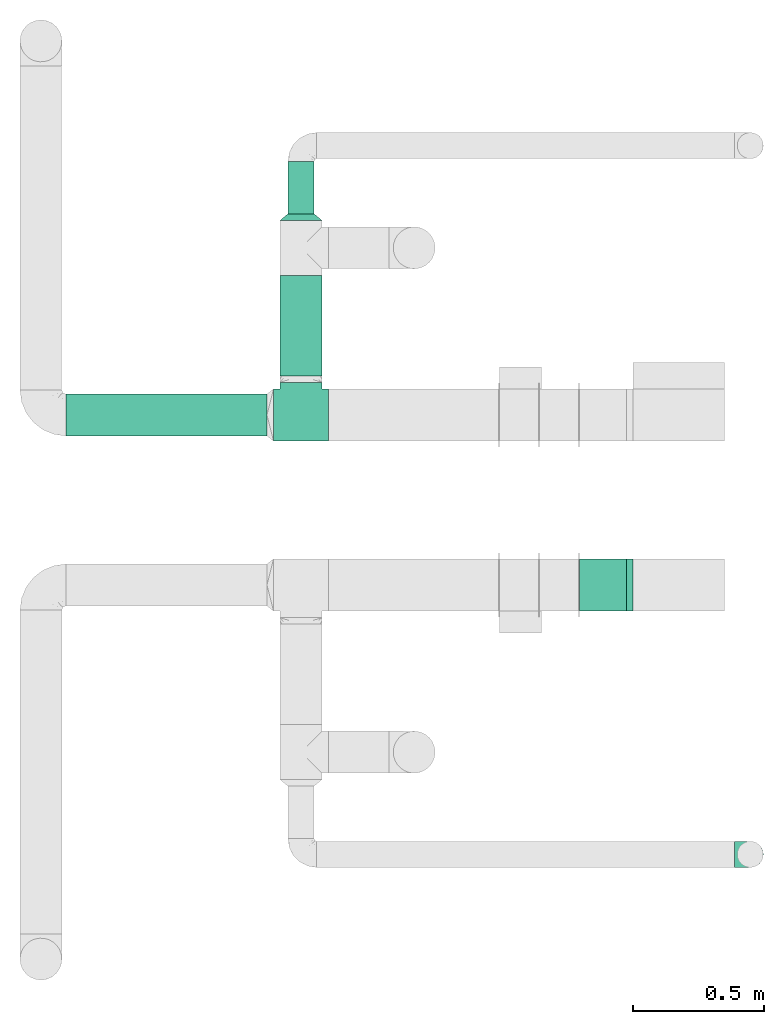
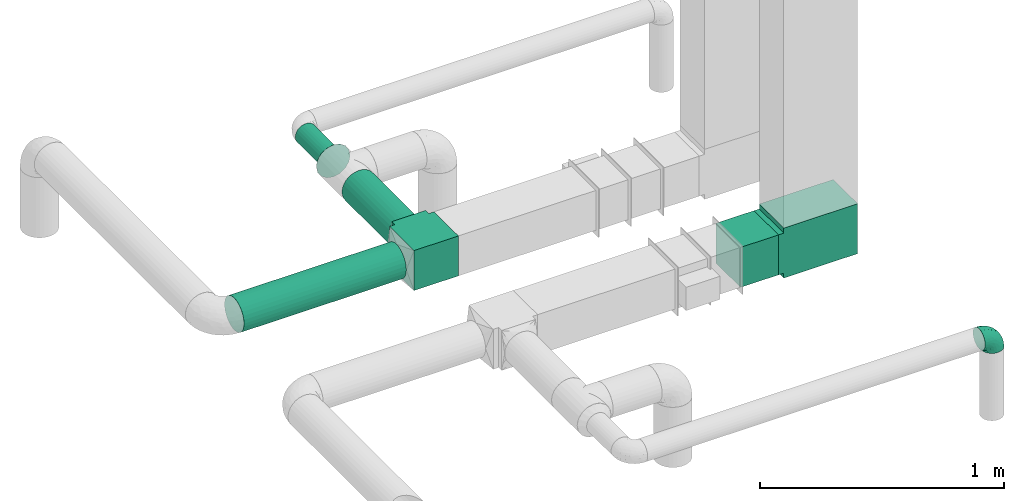
# One storey, part 6 of 12: 4 flow fittings, 4 flow segments.
"""IFC2X3 building model written with IfcOpenShell, lengths in millimetres."""

from ifc_helpers import new_model, entity, si_unit, converted_unit, derived_unit, direction, frame, frame_2d, origin, origin_2d_with_axis, place, context, subcontext, project, spatial, polyline, rectangle, circle, outline, extrude, faceted_brep, source, transform, mapped, material, type_object, type_shapes, element, save


model = new_model("IFC2X3")

# Units and contexts
model_context = context("Model", 3, precision=0.01, world=origin(), true_north=direction((6.12303176911189e-17, 1.0)))
body_context = subcontext(model_context, "Body", "Model", "MODEL_VIEW")
ifc_project = project(units=[si_unit("LENGTHUNIT", "METRE", prefix="MILLI"), si_unit("AREAUNIT", "SQUARE_METRE"), si_unit("VOLUMEUNIT", "CUBIC_METRE"), converted_unit("PLANEANGLEUNIT", "DEGREE", entity("IfcRatioMeasure", 0.0174532925199433), si_unit("PLANEANGLEUNIT", "RADIAN"), dimensions=[0, 0, 0, 0, 0, 0, 0]), si_unit("MASSUNIT", "GRAM", prefix="KILO"), derived_unit("MASSDENSITYUNIT", [(si_unit("MASSUNIT", "GRAM", prefix="KILO"), 1), (si_unit("LENGTHUNIT", "METRE"), -3)]), si_unit("TIMEUNIT", "SECOND"), si_unit("FREQUENCYUNIT", "HERTZ"), si_unit("THERMODYNAMICTEMPERATUREUNIT", "DEGREE_CELSIUS"), derived_unit("THERMALTRANSMITTANCEUNIT", [(si_unit("MASSUNIT", "GRAM", prefix="KILO"), 1), (si_unit("THERMODYNAMICTEMPERATUREUNIT", "KELVIN"), -1), (si_unit("TIMEUNIT", "SECOND"), -3)]), derived_unit("VOLUMETRICFLOWRATEUNIT", [(si_unit("LENGTHUNIT", "METRE"), 3), (si_unit("TIMEUNIT", "SECOND"), -1)]), si_unit("ELECTRICCURRENTUNIT", "AMPERE"), si_unit("ELECTRICVOLTAGEUNIT", "VOLT"), si_unit("POWERUNIT", "WATT"), si_unit("FORCEUNIT", "NEWTON", prefix="KILO"), si_unit("ILLUMINANCEUNIT", "LUX"), si_unit("LUMINOUSFLUXUNIT", "LUMEN"), si_unit("LUMINOUSINTENSITYUNIT", "CANDELA"), derived_unit("USERDEFINED", [(si_unit("MASSUNIT", "GRAM", prefix="KILO"), -1), (si_unit("LENGTHUNIT", "METRE"), -2), (si_unit("TIMEUNIT", "SECOND"), 3), (si_unit("LUMINOUSFLUXUNIT", "LUMEN"), 1)]), derived_unit("LINEARVELOCITYUNIT", [(si_unit("LENGTHUNIT", "METRE"), 1), (si_unit("TIMEUNIT", "SECOND"), -1)]), si_unit("PRESSUREUNIT", "PASCAL"), derived_unit("USERDEFINED", [(si_unit("LENGTHUNIT", "METRE"), -2), (si_unit("MASSUNIT", "GRAM", prefix="KILO"), 1), (si_unit("TIMEUNIT", "SECOND"), -2)])], contexts=[model_context])

# Site, building, storey
site_placement = place(None, origin())
site = spatial("IfcSite", under=ifc_project, at=site_placement, CompositionType="ELEMENT")
building_placement = place(site_placement, origin())
building = spatial("IfcBuilding", under=site, at=building_placement, CompositionType="ELEMENT")
storey_placement = place(building_placement, frame((0.0, 0.0, 4000.0)))
storey = spatial("IfcBuildingStorey", under=building, at=storey_placement, Name="01 Level", CompositionType="ELEMENT", Elevation=4000.0)

# Flow segments
duct_segment_type_1 = type_object("IfcDuctSegmentType", Name="Round Duct:Air", PredefinedType="NOTDEFINED")
flow_segment_1_placement = place(storey_placement, frame((22287.748982204, -68588.0392131986, 2918.40472776409)))
element("IfcFlowSegment", 1, at=flow_segment_1_placement, inside=storey, type_object=duct_segment_type_1, Name="Round Duct:Air", ObjectType="Round Duct:Air", context=body_context, shape_type="SweptSolid", body=[
    extrude(circle(Radius=80.0, at=origin_2d_with_axis()), frame((0.0, 81.5952722359237, 81.5952722359161), z_axis=(1.0, 0.0, 0.0), x_axis=(0.0, -1.0, 0.0)), (0.0, 0.0, 1.0), 768.241088647822),
])
flow_segment_2_placement = place(storey_placement, frame((23134.3947986159, -67737.2449387878, 2948.40472776403)))
element("IfcFlowSegment", 2, at=flow_segment_2_placement, inside=storey, type_object=duct_segment_type_1, Name="Round Duct:Air", ObjectType="Round Duct:Air", context=body_context, shape_type="SweptSolid", body=[
    extrude(circle(Radius=50.0, at=origin_2d_with_axis()), frame((51.5952722359175, 0.0, 51.5952722359164), z_axis=(0.0, 1.0, 0.0), x_axis=(-1.0, 0.0, 0.0)), (0.0, 0.0, 1.0), 200.701380999497),
])
flow_segment_3_placement = place(storey_placement, frame((23104.3947986159, -68356.4439409626, 2918.40472776409)))
element("IfcFlowSegment", 3, at=flow_segment_3_placement, inside=storey, type_object=duct_segment_type_1, Name="Round Duct:Air", ObjectType="Round Duct:Air", context=body_context, shape_type="SweptSolid", body=[
    extrude(circle(Radius=80.0, at=origin_2d_with_axis()), frame((81.595272235915, 0.0, 81.595272235915), z_axis=(0.0, 1.0, 0.0), x_axis=(-1.0, 0.0, 0.0)), (0.0, 0.0, 1.0), 384.199002174792),
])

# Flow fitting
duct_fitting_type_1 = type_object("IfcDuctFittingType", Name="Air_Elbow short_Circ", PredefinedType="NOTDEFINED")
shared_shape_1 = source(origin(), body_context, "Body", "Brep", [
    faceted_brep([(-60.0, 0.0, -50.0), (-60.0, -12.9409522551259, -48.2962913144534), (-60.0, -25.0, -43.3012701892219), (-60.0, -35.3553390593273, -35.3553390593274), (-60.0, -43.3012701892218, -25.0), (-60.0, -48.2962913144533, -12.9409522551262), (-60.0, -50.0, 0.0), (-60.0, -48.2962913144534, 12.9409522551259), (-60.0, -43.301270189222, 25.0), (-60.0, -35.3553390593275, 35.3553390593272), (-60.0, -25.0, 43.3012701892218), (-60.0, -12.9409522551262, 48.2962913144533), (-60.0, 0.0, 50.0), (-60.0, 12.9409522551258, 48.2962913144534), (-60.0, 18.9704761275628, 45.7987807518377), (-60.0, 25.0, 43.301270189222), (-60.0, 35.3553390593271, 35.3553390593275), (-60.0, 43.3012701892217, 25.0), (-60.0, 48.2962913144533, 12.9409522551263), (-60.0, 50.0, 0.0), (-60.0, 48.2962913144534, -12.940952255126), (-60.0, 43.3012701892219, -25.0), (-60.0, 35.3553390593274, -35.3553390593273), (-60.0, 25.0, -43.3012701892219), (-60.0, 12.9409522551261, -48.2962913144533), (-12.9409522551252, 60.0, -48.2962913144533), (-18.9704761275622, 60.0, -45.7987807518376), (-25.0, 60.0, -43.3012701892219), (-35.3553390593265, 60.0, -35.3553390593273), (-43.301270189221, 60.0, -25.0), (-48.2962913144525, 60.0, -12.940952255126), (-50.0, 60.0, 0.0), (-48.2962913144524, 60.0, 12.9409522551263), (-43.3012701892209, 60.0, 25.0), (-35.3553390593263, 60.0, 35.3553390593275), (-25.0, 60.0, 43.301270189222), (-12.9409522551249, 60.0, 48.2962913144534), (0.0, 60.0, 50.0), (12.9409522551271, 60.0, 48.2962913144533), (25.0, 60.0, 43.3012701892218), (35.3553390593284, 60.0, 35.3553390593272), (43.3012701892229, 60.0, 25.0), (48.2962913144543, 60.0, 12.9409522551259), (50.0, 60.0, 0.0), (48.2962913144542, 60.0, -12.9409522551262), (43.3012701892227, 60.0, -25.0), (35.3553390593281, 60.0, -35.3553390593274), (25.0, 60.0, -43.3012701892219), (12.9409522551268, 60.0, -48.2962913144534), (0.0, 60.0, -50.0), (-49.0564079906538, -40.7801415025898, 28.076858272246), (-41.7413930879589, -46.3367006663211, 14.3622192349088), (-34.4613055182162, -40.2781615499549, 24.6893391361235), (-43.0040653093767, -47.3081083962334, 0.0), (-49.945230570524, 14.009456366224, 48.3010541644054), (-46.9531334224505, 28.9691372331723, 42.5007483631415), (46.3367008388525, 41.7413924405609, 14.3622183025403), (-20.8886043148544, -37.032907476011, 22.5646988156665), (-16.4026032888538, -28.8335615486346, 31.3447155376829), (-28.9195822317624, -34.3595042325614, 30.8522337271345), (18.1051423029501, 18.6630708487668, 41.1725129713058), (21.5851347328685, 39.3600400603544, 43.7780030266717), (8.51327307359233, 29.8490270681828, 47.7425705251578), (-16.993357552601, 43.112835299455, 48.0588376259554), (-3.94145017646366, 44.1513377558611, 49.9695692624666), (-39.360041631582, -21.585137213725, 43.7780019122438), (-18.6630773197735, -18.1051465687322, 41.1725124591201), (-29.8490305613342, -8.51327565171467, 47.7425702287428), (-41.9572959526986, -32.3456520264411, 36.575294220854), (-28.3738768436699, -26.9110252548877, 38.0083212356069), (-51.9080682539527, 51.9080682564403, 11.9284381035673), (-47.8035915916317, 49.3365848090307, 24.1167211667097), (-28.9388870718402, 47.4392187660381, 42.4028289139121), (-46.4119732313288, -8.97786791845547, 48.9268647037242), (-0.0901680697707372, -16.249793899354, 33.6631038709893), (12.7026747916207, -16.0653579926251, 21.330563165355), (15.3655862372502, -1.44443599762982, 33.3656926605527), (-40.3512409746586, 17.2001159603688, 48.3058104561749), (-43.5357165770215, 3.92607608695299, 49.9756911723036), (-26.0984306641832, 9.4519602521943, 49.9925353018775), (-51.5116032222349, 38.9116886125261, 33.3337470302399), (32.3456522233896, 41.9572963751397, 36.5752941161915), (34.3595052098631, 28.9195768148052, 30.852230382061), (40.2781623134548, 34.4613024546835, 24.689336501659), (-52.6192947824697, 44.3162483434043, 26.0687788699409), (8.97786691245749, 46.4119718726044, 48.9268648562795), (35.0507691245895, 17.8379542600364, 23.7817320689175), (-10.9191638901366, -35.9593562872322, 14.7243484546897), (0.164802122834046, -30.9507973718637, 9.70158150296541), (-0.154113830211583, -27.0441585303382, 20.4371969134619), (40.7801421145919, 49.0564069362065, 28.0768572079665), (42.5446020921407, 25.3772134428819, 13.1791087429088), (10.303795037543, -23.1674391280597, 10.425151792526), (23.1044280783399, -10.2139010010231, 10.911201952746), (44.6162167924678, 26.008130618756, 0.0), (47.3081083962343, 43.0040653093781, 0.0), (-41.6246972537655, 41.624696659769, 36.6481760707585), (-32.7984308187714, 33.1644722725009, 45.0025999357929), (-7.74597844975689, 15.8760781607658, 49.2907901610601), (-16.0198594588589, 0.790040969679908, 48.0702532559686), (-10.2505184648613, 32.0701285913551, 49.9130990257927), (-52.9289321881336, 52.9289321881345, 0.0), (-38.9116885130941, 51.5116028691678, 33.3337472807585), (28.8335585354312, 16.4025932897411, 31.3447134244473), (27.3373523634918, 28.9262874076833, 37.8242669720924), (-10.6758764332908, -36.8040430868554, 0.0), (-21.0820556464647, 25.013405385062, 49.4085637061446), (-25.3772163464242, -42.5446022063287, 13.179111746218), (-29.4708300504911, 18.1716321771538, 49.3204506255928), (-0.613576836584022, 32.0726800049485, 49.6825501479137), (-26.0081306187546, -44.6162167924668, 0.0), (7.809323786389, 12.5506490133832, 44.518448707346), (-1.21981718883359, 1.21981162112378, 44.3295369128094), (4.65637775217312, -28.991869381244, 0.0), (25.4694098156993, -0.899564345657441, 21.9045256717261), (30.9271083665945, -0.192011278925337, 9.72551394481069), (36.8040430868565, 10.6758764332921, 0.0), (8.17237141004653, 0.709602060124845, 39.7363553078916), (-1.20691178924098, -8.42774890414073, 39.8368437988478), (-11.8311378719951, -8.12805454147699, 44.1670059112514), (16.8241235667092, -16.8241235667079, 0.0), (35.9593546638031, 10.9191599029529, 14.7243472530362), (28.9918693812452, -4.65637775217184, 0.0), (-14.0094588862512, 49.9452236085703, -48.3010539035587), (-41.7413926252934, -46.3367005832334, -14.3622192468898), (-34.4613048910139, -40.2781614393135, -24.6893390523416), (-25.3772156484835, -42.5446019119684, -13.1791119497906), (-43.1128355702084, 16.9933564311214, -48.0588378972243), (-44.1513388294639, 3.94144876101963, -49.969569299814), (-49.3365851024771, 47.8035917204495, -24.1167206397972), (-41.62469790636, 41.6246960630329, -36.6481760341003), (-51.5116035577561, 38.9116884747343, -33.3337470330805), (23.1674375203698, -10.3037953844737, -10.4251565011195), (10.2138986720569, -23.1044286164337, -10.9112068363266), (16.0653446591387, -12.7026862735946, -21.330566780897), (35.9593546209329, 10.9191616413996, -14.7243499458666), (30.9507965291521, -0.164803474452689, -9.70158128624016), (27.0441512446144, 0.154114142874967, -20.4372107139949), (-18.6630757642047, -18.1051470727615, -41.1725116507822), (-16.4026019873643, -28.8335613017021, -31.344715100551), (-28.9262923378956, -27.3373567288812, -37.8242648451571), (-15.8760743141415, 7.74597807562093, -49.2907896898935), (-9.45196719952168, 26.0984311316614, -49.9925354060889), (-0.79004904716724, 16.0198534732482, -48.0702540902608), (-25.0134056140136, 21.0820528609103, -49.4085640038716), (-49.0564077792961, -40.7801415002595, -28.0768582420378), (-47.4392196421628, 28.9388866268174, -42.4028289664685), (-33.1644687800828, 32.7984277324913, -45.0026021871039), (-51.9080682748156, 51.9080682458111, -11.9284380741106), (-41.9572952892088, -32.3456521258773, -36.5752940113004), (-39.3600407942016, -21.5851376014369, -43.7780015915287), (-29.8490289400598, -8.5132766456386, -47.7425697425162), (-46.411972568153, -8.97786849540185, -48.9268645575236), (-28.9195813138317, -34.3595041939927, -30.8522334076151), (-17.8379596675892, -35.0507702162708, -23.7817342784206), (21.5851368100191, 39.3600388626355, -43.7780017534797), (26.9110256448416, 28.3738769796432, -38.0083209621406), (18.1051443153088, 18.6630730295509, -41.1725124486671), (-38.911688364674, 51.5116023985273, -33.3337476311683), (-44.316248159738, 52.6192941440622, -26.0687795868405), (-17.2001201011705, 40.3512365316697, -48.3058099460363), (-3.92607321834031, 43.5357049838062, -49.9756913600445), (8.51327412363391, 29.8490256018375, -47.7425700423665), (8.97786798225732, 46.4119703958823, -48.9268645751331), (40.7801413413476, 49.0564079294803, -28.0768584987253), (-28.969136268001, 46.9531365639949, -42.5007481599507), (16.2497893015437, 0.0901603719773552, -33.6631026184802), (1.44442453081588, -15.3655954628303, -33.3656927670723), (32.3456517066656, 41.9572939682546, -36.5752941586943), (46.3367004266908, 41.7413922128929, -14.3622195286513), (34.3595039081184, 28.9195810717321, -30.8522336573022), (37.0329066484517, 20.888602858321, -22.564699256686), (28.8335602968518, 16.402602640196, -31.3447165791004), (40.2781610753798, 34.461304879185, -24.6893396682814), (-32.0701289123428, 10.2505155181949, -49.9130991682027), (42.5446013435109, 25.3772148558883, -13.1791129929581), (-18.17163862849, 29.4708285244359, -49.3204499074468), (-32.0726819537407, 0.61357350659226, -49.6825499006192), (-12.5506417422758, -7.80933382246174, -44.5184423716321), (-1.21981337419447, 1.21981084831843, -44.3295352204376), (0.899550937376629, -25.4694163362272, -21.9045307406697), (0.192009591001318, -30.9271092740971, -9.72551482732434), (-0.709596078235449, -8.17237239935393, -39.7363517396473), (8.42775025848031, 1.2069144200305, -39.8368443201002), (8.12805004108825, 11.8311369938791, -44.1670075921659), (-10.9191629014402, -35.9593557213529, -14.724348628576)], [[[0, 1, 2, 3, 4, 5, 6, 7, 8, 9, 10, 11, 12, 13, 14, 15, 16, 17, 18, 19, 20, 21, 22, 23, 24]], [[25, 26, 27, 28, 29, 30, 31, 32, 33, 34, 35, 36, 37, 38, 39, 40, 41, 42, 43, 44, 45, 46, 47, 48, 49]], [[50, 51, 52]], [[53, 7, 6]], [[54, 55, 15]], [[41, 56, 42]], [[57, 58, 59]], [[60, 61, 62]], [[36, 63, 64]], [[65, 66, 67]], [[10, 68, 65]], [[59, 69, 68]], [[70, 71, 32]], [[9, 8, 50]], [[35, 72, 63]], [[12, 11, 73]], [[74, 75, 76]], [[15, 14, 13, 54]], [[77, 78, 79]], [[11, 10, 65]], [[51, 8, 7]], [[16, 80, 17]], [[81, 82, 83]], [[80, 84, 17]], [[15, 55, 16]], [[35, 34, 72]], [[18, 70, 19]], [[65, 67, 73]], [[38, 37, 85]], [[84, 18, 17]], [[61, 38, 85]], [[82, 86, 83]], [[87, 88, 89]], [[38, 61, 39]], [[40, 90, 41]], [[64, 37, 36]], [[56, 83, 91]], [[56, 41, 90]], [[61, 81, 39]], [[92, 93, 75]], [[56, 94, 95]], [[72, 96, 97]], [[98, 79, 99]], [[100, 64, 63]], [[101, 19, 70]], [[10, 9, 68]], [[101, 70, 31]], [[65, 69, 66]], [[96, 102, 71]], [[60, 103, 104]], [[33, 102, 34]], [[88, 87, 105]], [[33, 32, 71]], [[63, 72, 97]], [[98, 106, 79]], [[36, 35, 63]], [[13, 12, 78]], [[107, 87, 57]], [[81, 40, 39]], [[83, 86, 91]], [[7, 53, 51]], [[95, 42, 56]], [[73, 78, 12]], [[108, 79, 106]], [[77, 108, 97]], [[80, 55, 96]], [[102, 72, 34]], [[96, 55, 97]], [[100, 63, 106]], [[64, 109, 85]], [[104, 81, 61]], [[90, 81, 83]], [[50, 68, 9]], [[59, 68, 52]], [[78, 67, 79]], [[110, 51, 53]], [[43, 42, 95]], [[99, 79, 67]], [[111, 98, 112]], [[100, 109, 64]], [[52, 51, 107]], [[88, 113, 92]], [[114, 93, 115]], [[103, 60, 76]], [[103, 76, 114]], [[116, 94, 91]], [[112, 117, 111]], [[76, 75, 114]], [[112, 118, 117]], [[119, 118, 112]], [[74, 66, 58]], [[99, 119, 112]], [[74, 58, 89]], [[76, 117, 118]], [[77, 97, 55]], [[63, 97, 106]], [[92, 113, 120]], [[114, 121, 86]], [[115, 93, 122]], [[122, 93, 120]], [[75, 93, 114]], [[93, 92, 120]], [[92, 75, 89]], [[74, 89, 75]], [[57, 89, 58]], [[64, 85, 37]], [[61, 85, 62]], [[65, 73, 11]], [[78, 73, 67]], [[51, 110, 107]], [[115, 116, 121]], [[91, 121, 116]], [[94, 56, 91]], [[71, 102, 33]], [[72, 102, 96]], [[55, 80, 16]], [[84, 96, 71]], [[106, 98, 100]], [[109, 98, 62]], [[98, 109, 100]], [[85, 109, 62]], [[89, 88, 92]], [[107, 105, 87]], [[96, 84, 80]], [[84, 71, 70]], [[70, 18, 84]], [[31, 70, 32]], [[51, 50, 8]], [[68, 50, 52]], [[81, 90, 40]], [[56, 90, 83]], [[54, 78, 77]], [[78, 54, 13]], [[54, 77, 55]], [[60, 104, 61]], [[82, 104, 103]], [[104, 82, 81]], [[86, 82, 103]], [[114, 86, 103]], [[86, 121, 91]], [[57, 59, 52]], [[69, 59, 58]], [[66, 69, 58]], [[68, 69, 65]], [[107, 57, 52]], [[57, 87, 89]], [[97, 108, 106]], [[77, 79, 108]], [[119, 67, 66]], [[98, 99, 112]], [[67, 119, 99]], [[118, 66, 74]], [[66, 118, 119]], [[76, 118, 74]], [[76, 60, 117]], [[111, 117, 60]], [[60, 62, 111]], [[98, 111, 62]], [[105, 107, 110]], [[113, 88, 105]], [[116, 115, 122]], [[114, 115, 121]], [[123, 27, 26, 25]], [[124, 125, 126]], [[23, 127, 24]], [[0, 24, 128]], [[129, 130, 131]], [[132, 133, 134]], [[21, 131, 22]], [[135, 136, 137]], [[21, 20, 129]], [[138, 139, 140]], [[141, 142, 143]], [[144, 142, 141]], [[124, 4, 145]], [[146, 130, 147]], [[124, 110, 53]], [[148, 129, 20]], [[149, 2, 150]], [[138, 150, 151]], [[1, 150, 2]], [[127, 146, 147]], [[23, 22, 146]], [[145, 4, 3]], [[3, 2, 149]], [[1, 152, 150]], [[153, 154, 125]], [[149, 153, 125]], [[19, 101, 148]], [[125, 154, 126]], [[31, 30, 148]], [[155, 156, 157]], [[29, 158, 159]], [[48, 47, 155]], [[136, 135, 116]], [[28, 158, 29]], [[146, 127, 23]], [[160, 161, 142]], [[155, 162, 163]], [[46, 45, 164]], [[28, 27, 165]], [[166, 134, 167]], [[48, 163, 49]], [[168, 155, 47]], [[24, 127, 128]], [[169, 45, 44]], [[170, 171, 172]], [[162, 155, 157]], [[1, 0, 152]], [[173, 164, 169]], [[25, 49, 161]], [[43, 95, 44]], [[47, 46, 168]], [[174, 128, 127]], [[170, 156, 168]], [[123, 165, 27]], [[4, 124, 5]], [[44, 95, 169]], [[148, 20, 19]], [[175, 135, 171]], [[159, 30, 29]], [[53, 5, 124]], [[163, 161, 49]], [[176, 142, 144]], [[160, 176, 147]], [[158, 165, 130]], [[131, 146, 22]], [[130, 165, 147]], [[174, 127, 144]], [[128, 177, 152]], [[140, 149, 150]], [[145, 149, 125]], [[164, 168, 46]], [[170, 168, 173]], [[161, 162, 142]], [[94, 169, 95]], [[6, 5, 53]], [[143, 142, 162]], [[178, 141, 179]], [[174, 177, 128]], [[173, 169, 175]], [[136, 122, 132]], [[180, 133, 181]], [[139, 138, 167]], [[139, 167, 180]], [[105, 110, 126]], [[179, 182, 178]], [[167, 134, 180]], [[179, 183, 182]], [[184, 183, 179]], [[166, 157, 172]], [[143, 184, 179]], [[166, 172, 137]], [[167, 182, 183]], [[160, 147, 165]], [[127, 147, 144]], [[132, 122, 120]], [[180, 185, 154]], [[181, 133, 113]], [[113, 133, 120]], [[134, 133, 180]], [[133, 132, 120]], [[132, 134, 137]], [[166, 137, 134]], [[171, 137, 172]], [[128, 152, 0]], [[150, 152, 151]], [[155, 163, 48]], [[161, 163, 162]], [[169, 94, 175]], [[181, 105, 185]], [[126, 185, 105]], [[110, 124, 126]], [[129, 131, 21]], [[146, 131, 130]], [[165, 158, 28]], [[159, 130, 129]], [[144, 141, 174]], [[177, 141, 151]], [[141, 177, 174]], [[152, 177, 151]], [[137, 136, 132]], [[175, 116, 135]], [[130, 159, 158]], [[159, 129, 148]], [[31, 148, 101]], [[148, 30, 159]], [[169, 164, 45]], [[168, 164, 173]], [[149, 145, 3]], [[124, 145, 125]], [[123, 161, 160]], [[161, 123, 25]], [[123, 160, 165]], [[138, 140, 150]], [[153, 140, 139]], [[140, 153, 149]], [[154, 153, 139]], [[180, 154, 139]], [[154, 185, 126]], [[171, 170, 173]], [[156, 170, 172]], [[157, 156, 172]], [[168, 156, 155]], [[175, 171, 173]], [[171, 135, 137]], [[147, 176, 144]], [[160, 142, 176]], [[184, 162, 157]], [[141, 143, 179]], [[162, 184, 143]], [[183, 157, 166]], [[157, 183, 184]], [[167, 183, 166]], [[167, 138, 182]], [[178, 182, 138]], [[138, 151, 178]], [[141, 178, 151]], [[116, 175, 94]], [[122, 136, 116]], [[105, 181, 113]], [[180, 181, 185]]]),
])
type_shapes(duct_fitting_type_1, [shared_shape_1])
flow_fitting_1_placement = place(storey_placement, frame((24903.4900708518, -70185.9356124915, 3000.0), z_axis=(0.0, -1.0, 0.0), x_axis=(0.0, 0.0, 1.0)))
element("IfcFlowFitting", 4, at=flow_fitting_1_placement, inside=storey, type_object=duct_fitting_type_1, Name="elbow_short_001:Air_Elbow short_Circ", ObjectType="elbow_short_001:Air_Elbow short_Circ", context=body_context, shape_type="MappedRepresentation", body=[
    mapped(shared_shape_1, transform((0.0, 0.0, 0.0), scale=1.0)),
])

# Flow segment
duct_segment_type_2 = type_object("IfcDuctSegmentType", Name="Rectangular Duct:Air", PredefinedType="NOTDEFINED")
flow_segment_4_placement = place(storey_placement, frame((24250.9900708518, -69256.0352293172, 2900.0)))
element("IfcFlowSegment", 5, at=flow_segment_4_placement, inside=storey, type_object=duct_segment_type_2, Name="Rectangular Duct:Air", ObjectType="Rectangular Duct:Air", context=body_context, shape_type="SweptSolid", body=[
    extrude(rectangle(XDim=179.671447124557, YDim=199.999999999998, at=frame_2d((0.0, -4.33431068813661e-12), x_axis=(1.0, 0.0))), frame((89.8357235622787, 100.0, 0.0)), (0.0, 0.0, 1.0), 200.0),
])

# Flow fittings
duct_fitting_type_2 = type_object("IfcDuctFittingType", Name="Air_Rect", PredefinedType="NOTDEFINED")
shared_shape_2 = source(origin(), body_context, "Body", "SweptSolid", [
    extrude(outline(polyline([(-125.0, 81.25), (-125.0, -268.75), (125.0, -268.75), (125.0, 81.2500000000001), (100.0, 81.2500000000001), (100.0, 106.25), (-100.0, 106.25), (-100.0, 81.25), (-125.0, 81.25)])), frame((0.0, -93.75, -100.0), z_axis=(0.0, 0.0, -1.0), x_axis=(1.0, 0.0, 0.0)), (0.0, 0.0, -1.0), 200.0),
])
type_shapes(duct_fitting_type_2, [shared_shape_2])
flow_fitting_2_placement = place(storey_placement, frame((24630.6615179764, -69156.0352293172, 3000.0), z_axis=(0.0, -1.0, 0.0), x_axis=(0.0, 0.0, -1.0)))
element("IfcFlowFitting", 6, at=flow_fitting_2_placement, inside=storey, type_object=duct_fitting_type_2, Name="1_001:Air_Rect", ObjectType="1_001:Air_Rect", context=body_context, shape_type="MappedRepresentation", body=[
    mapped(shared_shape_2, transform((0.0, 0.0, 0.0), scale=1.0)),
])
ifc_material = material(Name="Material_Duct")
duct_fitting_type_3 = type_object("IfcDuctFittingType", Name="Air_Reduction_Circ", PredefinedType="NOTDEFINED", material=ifc_material)
shared_shape_3 = source(origin(), body_context, "Body", "Brep", [
    faceted_brep([(25.0, 45.0484433951223, -21.6941869558729), (25.0, 47.5242216975607, -10.8470934779334), (25.0, 50.0, 0.0), (25.0, 47.5242216975601, 10.8470934779448), (25.0, 45.0484433951193, 21.6941869558836), (25.0, 38.1114667440265, 30.3928805396443), (25.0, 31.1744900929338, 39.0915741234051), (25.0, 21.1502683953737, 43.9189848662489), (25.0, 11.1260466978137, 48.7463956090927), (25.0, 0.0, 48.7463956090925), (25.0, -11.1260466978156, 48.7463956090923), (25.0, -21.1502683953754, 43.9189848662482), (25.0, -31.1744900929351, 39.0915741234041), (25.0, -38.1114667440274, 30.3928805396434), (25.0, -45.0484433951197, 21.6941869558827), (25.0, -47.5242216975603, 10.8470934779443), (25.0, -50.0, 0.0), (25.0, -47.5242216975608, -10.8470934779335), (25.0, -45.0484433951224, -21.6941869558726), (25.0, -38.1114667440309, -30.3928805396354), (25.0, -31.1744900929393, -39.0915741233981), (25.0, -21.1502683953783, -43.9189848662439), (25.0, -11.1260466978174, -48.7463956090898), (25.0, 0.0, -48.7463956090899), (25.0, 11.1260466978161, -48.74639560909), (25.0, 21.1502683953773, -43.9189848662444), (25.0, 31.1744900929385, -39.0915741233988), (25.0, 38.1114667440304, -30.3928805396358), (0.0, 80.0, 0.0), (0.0, 76.9551813004531, -15.307337294604), (0.0, 73.9103626009062, -30.6146745892082), (0.0, 65.2394525479173, -43.5916085420681), (0.0, 56.5685424949284, -56.5685424949279), (0.0, 43.5916085420694, -65.2394525479189), (0.0, 30.6146745892104, -73.9103626009099), (0.0, 15.3073372946054, -76.9551813004588), (0.0, 0.0, -80.0), (0.0, -15.3073372946045, -76.9551813004584), (0.0, -30.6146745892093, -73.9103626009091), (0.0, -43.5916085420678, -65.239452547918), (0.0, -56.5685424949263, -56.568542494927), (0.0, -65.2394525479148, -43.5916085420674), (0.0, -73.9103626009034, -30.6146745892079), (0.0, -76.9551813004502, -15.3073372946042), (0.0, -80.0, 0.0), (0.0, -76.9551813004499, 15.3073372946029), (0.0, -73.9103626008998, 30.6146745892058), (0.0, -65.2394525479096, 43.5916085420626), (0.0, -56.5685424949195, 56.5685424949194), (0.0, -43.5916085420619, 65.2394525479076), (0.0, -30.6146745892043, 73.9103626008959), (0.0, -15.3073372946022, 76.955181300444), (0.0, 0.0, 80.0), (0.0, 15.3073372946022, 76.9551813004446), (0.0, 30.6146745892045, 73.910362600897), (0.0, 43.5916085420627, 65.2394525479091), (0.0, 56.5685424949208, 56.5685424949211), (0.0, 65.2394525479115, 43.5916085420641), (0.0, 73.9103626009022, 30.6146745892071), (0.0, 76.9551813004526, 15.3073372946037)], [[[0, 1, 2, 3, 4, 5, 6, 7, 8, 9, 10, 11, 12, 13, 14, 15, 16, 17, 18, 19, 20, 21, 22, 23, 24, 25, 26, 27]], [[28, 29, 30, 31, 32, 33, 34, 35, 36, 37, 38, 39, 40, 41, 42, 43, 44, 45, 46, 47, 48, 49, 50, 51, 52, 53, 54, 55, 56, 57, 58, 59]], [[17, 42, 18]], [[38, 21, 39]], [[18, 42, 41]], [[27, 32, 31]], [[23, 35, 24]], [[22, 37, 23]], [[33, 32, 26]], [[41, 19, 18]], [[44, 43, 16]], [[35, 23, 36]], [[20, 39, 21]], [[43, 17, 16]], [[22, 21, 38]], [[33, 26, 25]], [[1, 29, 2]], [[30, 0, 31]], [[35, 34, 24]], [[41, 40, 19]], [[40, 20, 19]], [[24, 34, 25]], [[25, 34, 33]], [[27, 31, 0]], [[43, 42, 17]], [[27, 26, 32]], [[0, 30, 1]], [[22, 38, 37]], [[28, 2, 29]], [[36, 23, 37]], [[1, 30, 29]], [[20, 40, 39]], [[3, 58, 4]], [[54, 7, 55]], [[4, 58, 57]], [[13, 48, 47]], [[9, 51, 10]], [[8, 53, 9]], [[49, 48, 12]], [[57, 5, 4]], [[28, 59, 2]], [[51, 9, 52]], [[6, 55, 7]], [[59, 3, 2]], [[8, 7, 54]], [[49, 12, 11]], [[15, 45, 16]], [[46, 14, 47]], [[51, 50, 10]], [[57, 56, 5]], [[56, 6, 5]], [[10, 50, 11]], [[11, 50, 49]], [[13, 47, 14]], [[59, 58, 3]], [[13, 12, 48]], [[14, 46, 15]], [[8, 54, 53]], [[44, 16, 45]], [[52, 9, 53]], [[15, 46, 45]], [[6, 56, 55]]]),
])
type_shapes(duct_fitting_type_3, [shared_shape_3])
flow_fitting_3_placement = place(storey_placement, frame((23185.9900708518, -67762.2449387878, 3000.0), z_axis=(0.0, 0.0, 1.0), x_axis=(0.0, 1.0, 0.0)))
element("IfcFlowFitting", 7, at=flow_fitting_3_placement, inside=storey, type_object=duct_fitting_type_3, material=ifc_material, Name="reduction_001:Air_Reduction_Circ", ObjectType="reduction_001:Air_Reduction_Circ", context=body_context, shape_type="MappedRepresentation", body=[
    mapped(shared_shape_3, transform((0.0, 0.0, 0.0), scale=1.0)),
])
duct_fitting_type_4 = type_object("IfcDuctFittingType", Name="Air_Rect", PredefinedType="NOTDEFINED")
shared_shape_4 = source(origin(), body_context, "Body", "SweptSolid", [
    extrude(outline(polyline([(-43.7499999999997, -105.0), (156.25, -105.0), (156.25, 105.0), (-43.7500000000004, 105.0), (-43.7500000000003, 80.0), (-68.7499999999999, 80.0), (-68.7499999999999, -80.0), (-43.7499999999998, -80.0), (-43.7499999999997, -105.0)])), frame((0.0, 56.25, -100.0), z_axis=(0.0, 0.0, 1.0), x_axis=(0.0, -1.0, 0.0)), (0.0, 0.0, 1.0), 200.0),
])
type_shapes(duct_fitting_type_4, [shared_shape_4])
flow_fitting_4_placement = place(storey_placement, frame((23185.9900708518, -68506.4439409626, 3000.0)))
element("IfcFlowFitting", 8, at=flow_fitting_4_placement, inside=storey, type_object=duct_fitting_type_4, Name="1_001:Air_Rect", ObjectType="1_001:Air_Rect", context=body_context, shape_type="MappedRepresentation", body=[
    mapped(shared_shape_4, transform((0.0, 0.0, 0.0), scale=1.0)),
])

save(model, "model.ifc")
